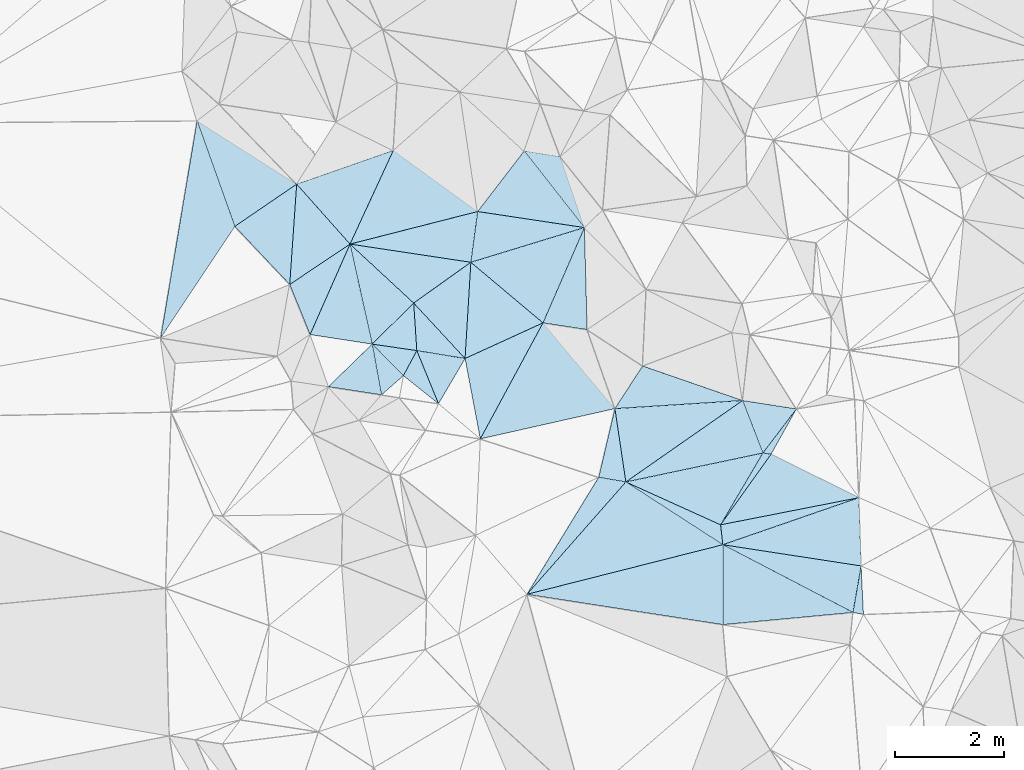
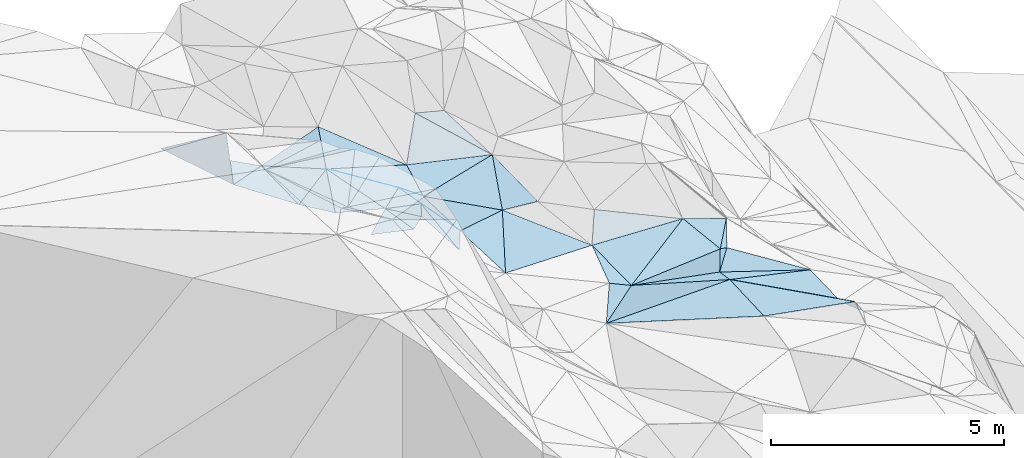
# One storey, part 135 of 275: 45 plates.
"""IFC2X3 building model written with IfcOpenShell, lengths in millimetres."""

import ifcopenshell
import ifcopenshell.guid

model = None  # the IFC model being written
_history = None  # IfcOwnerHistory: only IFC2X3 demands one
_inside = {}  # id of a spatial element -> (the spatial element, [elements in it])
_under = {}  # id of a project, library or spatial element -> (it, [spatial elements below it])
_declared = {}  # id of a project -> (the project, [libraries it declares])
_typed = {}  # id of a type object -> (the type object, [elements of that type])
_made_of = {}  # id of a material, layer set ... -> (it, [elements and type objects made of it])


def new_model(schema):
    """Start an empty IFC model of exactly this schema.

    Asked for "IFC4X3", IfcOpenShell would pick the latest addendum, in which some entities
    have other attributes; the version numbers below select the first issue.
    IFC2X3 requires an IfcOwnerHistory on every rooted entity: one is made here for all.
    """
    global model, _history
    if schema == "IFC4X3":
        model = ifcopenshell.file(schema_version=(4, 3, 0, 0))
    else:
        model = ifcopenshell.file(schema=schema)
    _inside.clear()
    _under.clear()
    _declared.clear()
    _typed.clear()
    _made_of.clear()
    _history = None
    if model.schema == "IFC2X3":
        org = make("IfcOrganization", Name="unknown")
        user = make(
            "IfcPersonAndOrganization",
            ThePerson=make("IfcPerson", FamilyName="unknown"),
            TheOrganization=org,
        )
        app = make(
            "IfcApplication",
            ApplicationDeveloper=org,
            Version="unknown",
            ApplicationFullName="unknown",
            ApplicationIdentifier="unknown",
        )
        _history = make(
            "IfcOwnerHistory",
            OwningUser=user,
            OwningApplication=app,
            ChangeAction="ADDED",
            CreationDate=0,
        )
    return model


def make(cls, **values):
    """One entity of the class cls with the attributes given. An attribute that is None is left unset."""
    return model.create_entity(
        cls, **{name: value for name, value in values.items() if value is not None}
    )


def rooted(cls, **values):
    """An entity with a GlobalId (a new one), such as an element, a storey or a relation."""
    return make(cls, GlobalId=ifcopenshell.guid.new(), OwnerHistory=_history, **values)


def si_unit(unit_type, name, prefix=None):
    """IfcSIUnit, for example si_unit("LENGTHUNIT", "METRE", prefix="MILLI")."""
    return make("IfcSIUnit", UnitType=unit_type, Prefix=prefix, Name=name)


def assignment(units):
    """IfcUnitAssignment: the units of a project."""
    return None if units is None else make("IfcUnitAssignment", Units=units)


def point(xyz):
    """IfcCartesianPoint."""
    return None if xyz is None else make("IfcCartesianPoint", Coordinates=xyz)


def direction(xyz):
    """IfcDirection."""
    return None if xyz is None else make("IfcDirection", DirectionRatios=xyz)


def frame(location, z_axis=None, x_axis=None):
    """IfcAxis2Placement3D, a coordinate frame: its origin and axes. An axis left out is left unset."""
    return make(
        "IfcAxis2Placement3D",
        Location=point(location),
        Axis=direction(z_axis),
        RefDirection=direction(x_axis),
    )


def origin_with_axes():
    """The frame at (0, 0, 0) with the z axis (0, 0, 1) and the x axis (1, 0, 0) written out."""
    return frame((0.0, 0.0, 0.0), z_axis=(0.0, 0.0, 1.0), x_axis=(1.0, 0.0, 0.0))


def place(relative_to, where):
    """IfcLocalPlacement: puts the frame where relative to a parent placement (None: the world)."""
    return make(
        "IfcLocalPlacement", PlacementRelTo=relative_to, RelativePlacement=where
    )


def context(
    kind, dimensions, precision=None, world=None, true_north=None, identifier=None
):
    """IfcGeometricRepresentationContext, for example the 3D "Model" context."""
    return make(
        "IfcGeometricRepresentationContext",
        ContextIdentifier=identifier,
        ContextType=kind,
        CoordinateSpaceDimension=dimensions,
        Precision=precision,
        WorldCoordinateSystem=world,
        TrueNorth=true_north,
    )


def subcontext(parent, identifier, kind, view, scale=None):
    """IfcGeometricRepresentationSubContext, for example "Body" below "Model"."""
    return make(
        "IfcGeometricRepresentationSubContext",
        ContextIdentifier=identifier,
        ContextType=kind,
        ParentContext=parent,
        TargetScale=scale,
        TargetView=view,
    )


def project(units=None, contexts=None):
    """IfcProject with its units and contexts."""
    return rooted(
        "IfcProject",
        Name="project",
        RepresentationContexts=contexts,
        UnitsInContext=assignment(units),
    )


def spatial(cls, under=None, at=None, **own):
    """A site, building, storey or space (cls), placed at a placement, below another one or the project."""
    s = rooted(cls, ObjectPlacement=at, **own)
    if under is not None:
        _under.setdefault(under.id(), (under, []))[1].append(s)
    return s


def polyline(points):
    """IfcPolyline through the points."""
    return make("IfcPolyline", Points=[point(p) for p in points])


def outline(outer, holes=None, kind="AREA"):
    """IfcArbitraryClosedProfileDef: a profile drawn as a closed curve; with holes, ...WithVoids."""
    if holes is None:
        return make("IfcArbitraryClosedProfileDef", ProfileType=kind, OuterCurve=outer)
    return make(
        "IfcArbitraryProfileDefWithVoids",
        ProfileType=kind,
        OuterCurve=outer,
        InnerCurves=holes,
    )


def extrude(swept, where, along, depth):
    """IfcExtrudedAreaSolid: the profile swept, set in the frame where, extruded along a direction by depth."""
    return make(
        "IfcExtrudedAreaSolid",
        SweptArea=swept,
        Position=where,
        ExtrudedDirection=direction(along),
        Depth=depth,
    )


def shape(context_of_items, identifier, shape_type, items):
    """IfcShapeRepresentation: the items that make up one representation, for example the "Body"."""
    return make(
        "IfcShapeRepresentation",
        ContextOfItems=context_of_items,
        RepresentationIdentifier=identifier,
        RepresentationType=shape_type,
        Items=items,
    )


def material(Name=None, Category=None):
    """IfcMaterial."""
    return make("IfcMaterial", Name=Name, Category=Category)


def made_of(thing, what):
    """Note that an element or type object is made of a material, layer set ...; save() writes the relation."""
    if what is not None:
        _made_of.setdefault(what.id(), (what, []))[1].append(thing)
    return thing


def type_object(cls, material=None, **own):
    """A type object (cls), such as IfcWallType, which elements share."""
    return made_of(rooted(cls, **own), material)


def element(
    cls,
    number,
    at=None,
    inside=None,
    cuts=None,
    type_object=None,
    material=None,
    context=None,
    identifier="Body",
    shape_type=None,
    held_by="IfcProductDefinitionShape",
    body=None,
    shapes=None,
    **own,
):
    """One element of the class cls, such as IfcWall. Its Tag is "e" and its number.

    at: its placement. inside: the storey or other place that contains it. cuts: it is an
    opening in that element (IfcRelVoidsElement). A single representation is given by context,
    identifier, shape_type and body (its items); several are given by shapes. held_by: the class
    of the entity that holds the representations. save() writes the other relations.
    """
    e = rooted(cls, Tag="e%d" % number, ObjectPlacement=at, **own)
    if body is not None:
        shapes = [shape(context, identifier, shape_type, body)]
    if shapes is not None:
        e.Representation = make(held_by, Representations=shapes)
    if inside is not None:
        _inside.setdefault(inside.id(), (inside, []))[1].append(e)
    if cuts is not None:
        rooted(
            "IfcRelVoidsElement", RelatingBuildingElement=cuts, RelatedOpeningElement=e
        )
    if type_object is not None:
        _typed.setdefault(type_object.id(), (type_object, []))[1].append(e)
    return made_of(e, material)


def aggregate(whole, parts):
    """IfcRelAggregates: a whole, such as a stair, and the parts it consists of."""
    return rooted("IfcRelAggregates", RelatingObject=whole, RelatedObjects=parts)


def save(model, path):
    """Write the relations noted so far, then the file.

    IfcRelAggregates (storeys below a building ...), IfcRelContainedInSpatialStructure (elements
    in a storey), IfcRelDefinesByType, IfcRelAssociatesMaterial and IfcRelDeclares: one each for
    every whole, place, type object, material and project.
    """
    for whole, parts in _under.values():
        aggregate(whole, parts)
    for where, things in _inside.values():
        rooted(
            "IfcRelContainedInSpatialStructure",
            RelatedElements=things,
            RelatingStructure=where,
        )
    for kind, things in _typed.values():
        rooted("IfcRelDefinesByType", RelatedObjects=things, RelatingType=kind)
    for what, things in _made_of.values():
        rooted("IfcRelAssociatesMaterial", RelatedObjects=things, RelatingMaterial=what)
    for by, libraries in _declared.values():
        rooted("IfcRelDeclares", RelatingContext=by, RelatedDefinitions=libraries)
    model.write(path)


model = new_model("IFC2X3")

# Units and contexts
model_context = context("Model", 3, precision=1e-05, world=origin_with_axes())
body_context = subcontext(model_context, "Body", "Model", "MODEL_VIEW")
ifc_project = project(units=[si_unit("LENGTHUNIT", "METRE", prefix="MILLI"), si_unit("AREAUNIT", "SQUARE_METRE"), si_unit("VOLUMEUNIT", "CUBIC_METRE"), si_unit("MASSUNIT", "GRAM", prefix="KILO"), si_unit("TIMEUNIT", "SECOND"), si_unit("PLANEANGLEUNIT", "RADIAN"), si_unit("SOLIDANGLEUNIT", "STERADIAN"), si_unit("THERMODYNAMICTEMPERATUREUNIT", "DEGREE_CELSIUS"), si_unit("LUMINOUSINTENSITYUNIT", "LUMEN")], contexts=[model_context])

# Site, building, storey
site_placement = place(None, origin_with_axes())
site = spatial("IfcSite", under=ifc_project, at=site_placement, CompositionType="ELEMENT")
building_placement = place(site_placement, origin_with_axes())
building = spatial("IfcBuilding", under=site, at=building_placement, Name="Undefined", CompositionType="ELEMENT")
storey_placement = place(building_placement, origin_with_axes())
storey = spatial("IfcBuildingStorey", under=building, at=storey_placement, Name="Undefined", CompositionType="ELEMENT", Elevation=0.0)

# Plates
ifc_material = material()
plate_type_1 = type_object("IfcPlateType", PredefinedType="NOTDEFINED")
plate_1_placement = place(storey_placement, frame((-107710.69176452, 128511.918130305, 52359.5023639897), z_axis=(-0.0371328837966639, 0.0902431550285866, -0.995227271486986), x_axis=(-0.762830735926998, 0.640777467398013, 0.0865650368223972)))
element("IfcPlate", 1, at=plate_1_placement, inside=storey, type_object=plate_type_1, material=ifc_material, Name="00", context=body_context, shape_type="SweptSolid", body=[
    extrude(outline(polyline([(0.0, 0.0), (1732.80114746094, -1.14378053694963e-08), (551.130737304688, 1826.81555175781), (0.0, 0.0)])), frame((-8.85201319254618e-08, 2.18876761149539e-07, -0.5000001331573), z_axis=(0.0, 0.0, 1.0), x_axis=(1.0, 0.0, 0.0)), (0.0, 0.0, 1.0), 1.0),
])
plate_type_2 = type_object("IfcPlateType", PredefinedType="NOTDEFINED")
plate_2_placement = place(storey_placement, frame((-109138.864228995, 127858.741128758, 52709.6383195385), z_axis=(-0.689324173895359, -0.0405942990156006, -0.723314790510268), x_axis=(-0.58104888926832, 0.627295977761669, 0.518538276855318)))
element("IfcPlate", 2, at=plate_2_placement, inside=storey, type_object=plate_type_2, material=ifc_material, Name="00", context=body_context, shape_type="SweptSolid", body=[
    extrude(outline(polyline([(0.0, 0.0), (1619.93823242188, -3.40151018463075e-09), (940.900024414063, 1508.54467773438), (0.0, 0.0)])), frame((-8.85201319254618e-08, 2.18876761149539e-07, -0.5000001331573), z_axis=(0.0, 0.0, 1.0), x_axis=(1.0, 0.0, 0.0)), (0.0, 0.0, 1.0), 1.0),
])
plate_type_3 = type_object("IfcPlateType", PredefinedType="NOTDEFINED")
plate_3_placement = place(storey_placement, frame((-106192.409003258, 125596.978377253, 51619.5136560321), z_axis=(-0.100611439804562, 0.209387360971227, -0.972642931011149), x_axis=(-0.143834742344254, 0.964272473574274, 0.222463847853337)))
element("IfcPlate", 3, at=plate_3_placement, inside=storey, type_object=plate_type_3, material=ifc_material, Name="00", context=body_context, shape_type="SweptSolid", body=[
    extrude(outline(polyline([(0.0, 0.0), (1393.48486328125, 1.04482751339674e-08), (1153.65441894531, 2341.5126953125), (0.0, 0.0)])), frame((-8.85201319254618e-08, 2.18876761149539e-07, -0.5000001331573), z_axis=(0.0, 0.0, 1.0), x_axis=(1.0, 0.0, 0.0)), (0.0, 0.0, 1.0), 1.0),
])
plate_type_4 = type_object("IfcPlateType", PredefinedType="NOTDEFINED")
plate_4_placement = place(storey_placement, frame((-108859.292674033, 126386.029390544, 52399.5278280914), z_axis=(-0.296645922713064, 0.142488007224602, -0.944297815487718), x_axis=(-0.182504648304248, 0.962123439443059, 0.2025105938503)))
element("IfcPlate", 4, at=plate_4_placement, inside=storey, type_object=plate_type_4, material=ifc_material, Name="00", context=body_context, shape_type="SweptSolid", body=[
    extrude(outline(polyline([(0.0, 0.0), (1530.78405761719, 7.29050952941179e-09), (1827.69079589844, 1581.02697753906), (0.0, 0.0)])), frame((-8.85201319254618e-08, 2.18876761149539e-07, -0.5000001331573), z_axis=(0.0, 0.0, 1.0), x_axis=(1.0, 0.0, 0.0)), (0.0, 0.0, 1.0), 1.0),
])
plate_type_5 = type_object("IfcPlateType", PredefinedType="NOTDEFINED")
plate_5_placement = place(storey_placement, frame((-101921.569591714, 125309.296885175, 50709.5498930315), z_axis=(-0.431603792133785, 0.0584415224361357, -0.900168181547806), x_axis=(0.0311991043474354, -0.996335009214666, -0.0796439909919763)))
element("IfcPlate", 5, at=plate_5_placement, inside=storey, type_object=plate_type_5, material=ifc_material, Name="00", context=body_context, shape_type="SweptSolid", body=[
    extrude(outline(polyline([(0.0, 0.0), (1255.58752441406, 9.02218744158745e-10), (690.433776855469, 2790.73486328125), (0.0, 0.0)])), frame((-8.85201319254618e-08, 2.18876761149539e-07, -0.5000001331573), z_axis=(0.0, 0.0, 1.0), x_axis=(1.0, 0.0, 0.0)), (0.0, 0.0, 1.0), 1.0),
])
plate_type_6 = type_object("IfcPlateType", PredefinedType="NOTDEFINED")
plate_6_placement = place(storey_placement, frame((-104413.620050964, 122982.94455354, 51779.5098386131), z_axis=(-0.192062091809998, 0.0465779168700106, -0.980276823427759), x_axis=(-0.968897039972385, 0.149828539683579, 0.196951604789191)))
element("IfcPlate", 6, at=plate_6_placement, inside=storey, type_object=plate_type_6, material=ifc_material, Name="00", context=body_context, shape_type="SweptSolid", body=[
    extrude(outline(polyline([(0.0, 0.0), (3706.49438476563, 1.20489858090878e-08), (235.28971862793, 1446.80297851563), (0.0, 0.0)])), frame((-8.85201319254618e-08, 2.18876761149539e-07, -0.5000001331573), z_axis=(0.0, 0.0, 1.0), x_axis=(1.0, 0.0, 0.0)), (0.0, 0.0, 1.0), 1.0),
])
plate_type_7 = type_object("IfcPlateType", PredefinedType="NOTDEFINED")
plate_7_placement = place(storey_placement, frame((-106392.944822617, 126940.657635162, 51929.5321163041), z_axis=(-0.309209619517044, 0.169753804659345, -0.935720608409263), x_axis=(0.143834742311184, -0.964272473579365, -0.222463847852651)))
element("IfcPlate", 7, at=plate_7_placement, inside=storey, type_object=plate_type_7, material=ifc_material, Name="00", context=body_context, shape_type="SweptSolid", body=[
    extrude(outline(polyline([(0.0, 0.0), (1393.48486328125, 1.04482751339674e-08), (1198.72131347656, 499.266632080078), (0.0, 0.0)])), frame((-8.85201319254618e-08, 2.18876761149539e-07, -0.5000001331573), z_axis=(0.0, 0.0, 1.0), x_axis=(1.0, 0.0, 0.0)), (0.0, 0.0, 1.0), 1.0),
])
plate_type_8 = type_object("IfcPlateType", PredefinedType="NOTDEFINED")
plate_8_placement = place(storey_placement, frame((-111246.436842122, 129955.526503415, 53799.512210554), z_axis=(-0.219560814222345, -0.0113309706009984, -0.975533012236521), x_axis=(0.724715379181477, -0.671316362592735, -0.155312460842994)))
element("IfcPlate", 8, at=plate_8_placement, inside=storey, type_object=plate_type_8, material=ifc_material, Name="00", context=body_context, shape_type="SweptSolid", body=[
    extrude(outline(polyline([(0.0, 0.0), (1609.65832519531, -3.08500602841377e-09), (1534.98413085938, 1082.23095703125), (0.0, 0.0)])), frame((-8.85201319254618e-08, 2.18876761149539e-07, -0.5000001331573), z_axis=(0.0, 0.0, 1.0), x_axis=(1.0, 0.0, 0.0)), (0.0, 0.0, 1.0), 1.0),
])
plate_type_9 = type_object("IfcPlateType", PredefinedType="NOTDEFINED")
plate_9_placement = place(storey_placement, frame((-112223.908202513, 131053.984974895, 53559.5071888901), z_axis=(0.146227209778947, -0.0851880249528446, -0.985576279911858), x_axis=(0.656143795974726, -0.737245238415786, 0.161073826046096)))
element("IfcPlate", 9, at=plate_9_placement, inside=storey, type_object=plate_type_9, material=ifc_material, Name="00", context=body_context, shape_type="SweptSolid", body=[
    extrude(outline(polyline([(0.0, 0.0), (1490.0, 3.95539245801046e-09), (1294.36242675781, 1319.36572265625), (0.0, 0.0)])), frame((-8.85201319254618e-08, 2.18876761149539e-07, -0.5000001331573), z_axis=(0.0, 0.0, 1.0), x_axis=(1.0, 0.0, 0.0)), (0.0, 0.0, 1.0), 1.0),
])
plate_type_10 = type_object("IfcPlateType", PredefinedType="NOTDEFINED")
plate_10_placement = place(storey_placement, frame((-102030.288369506, 123205.455464031, 51189.6131706941), z_axis=(-0.447477321364182, -0.448650769825437, -0.773612650878836), x_axis=(-0.861524801288728, 0.448293993777246, 0.238343264867428)))
element("IfcPlate", 10, at=plate_10_placement, inside=storey, type_object=plate_type_10, material=ifc_material, Name="00", context=body_context, shape_type="SweptSolid", body=[
    extrude(outline(polyline([(0.0, 0.0), (2769.11547851563, -1.03682396002114e-08), (116.57152557373, 1035.1865234375), (0.0, 0.0)])), frame((-8.85201319254618e-08, 2.18876761149539e-07, -0.5000001331573), z_axis=(0.0, 0.0, 1.0), x_axis=(1.0, 0.0, 0.0)), (0.0, 0.0, 1.0), 1.0),
])
plate_type_11 = type_object("IfcPlateType", PredefinedType="NOTDEFINED")
plate_11_placement = place(storey_placement, frame((-103682.49230924, 126127.162952142, 51379.5272046954), z_axis=(-0.19937264125571, 0.257278735910264, -0.945546509679528), x_axis=(-0.341441807250448, 0.886210075497294, 0.313128079783064)))
element("IfcPlate", 11, at=plate_11_placement, inside=storey, type_object=plate_type_11, material=ifc_material, Name="00", context=body_context, shape_type="SweptSolid", body=[
    extrude(outline(polyline([(0.0, 0.0), (1085.81762695313, -9.53150447458029e-10), (533.975463867188, 869.005310058594), (0.0, 0.0)])), frame((-8.85201319254618e-08, 2.18876761149539e-07, -0.5000001331573), z_axis=(0.0, 0.0, 1.0), x_axis=(1.0, 0.0, 0.0)), (0.0, 0.0, 1.0), 1.0),
])
plate_type_12 = type_object("IfcPlateType", PredefinedType="NOTDEFINED")
plate_12_placement = place(storey_placement, frame((-101882.599243838, 124058.181508393, 50609.7457046321), z_axis=(-0.83731341803122, -0.20071661937462, -0.508546043826613), x_axis=(0.0460346862465202, -0.952751163974088, 0.30024328003838)))
element("IfcPlate", 12, at=plate_12_placement, inside=storey, type_object=plate_type_12, material=ifc_material, Name="00", context=body_context, shape_type="SweptSolid", body=[
    extrude(outline(polyline([(0.0, 0.0), (932.577087402344, -4.13274392485619e-09), (979.650939941406, 354.237274169922), (0.0, 0.0)])), frame((-8.85201319254618e-08, 2.18876761149539e-07, -0.5000001331573), z_axis=(0.0, 0.0, 1.0), x_axis=(1.0, 0.0, 0.0)), (0.0, 0.0, 1.0), 1.0),
])
plate_type_13 = type_object("IfcPlateType", PredefinedType="NOTDEFINED")
plate_13_placement = place(storey_placement, frame((-103066.543422273, 126935.130052878, 51469.5057783137), z_axis=(-0.0456164725970412, 0.14485958604329, -0.988400140509485), x_axis=(-0.486392299623848, -0.867446613134529, -0.104684785083886)))
element("IfcPlate", 13, at=plate_13_placement, inside=storey, type_object=plate_type_13, material=ifc_material, Name="00", context=body_context, shape_type="SweptSolid", body=[
    extrude(outline(polyline([(0.0, 0.0), (955.248657226563, 4.16184775531292e-09), (1009.89410400391, 142.877136230469), (0.0, 0.0)])), frame((-8.85201319254618e-08, 2.18876761149539e-07, -0.5000001331573), z_axis=(0.0, 0.0, 1.0), x_axis=(1.0, 0.0, 0.0)), (0.0, 0.0, 1.0), 1.0),
])
plate_type_14 = type_object("IfcPlateType", PredefinedType="NOTDEFINED")
plate_14_placement = place(storey_placement, frame((-104415.923575617, 124447.0228709, 51849.5418899047), z_axis=(-0.394721021591551, -0.0694235471478252, -0.916174484590755), x_axis=(-0.111476295290039, 0.993393499615418, -0.0272468440418521)))
element("IfcPlate", 14, at=plate_14_placement, inside=storey, type_object=plate_type_14, material=ifc_material, Name="00", context=body_context, shape_type="SweptSolid", body=[
    extrude(outline(polyline([(0.0, 0.0), (367.014984130859, 1.74622982740402e-10), (609.511901855469, 2809.51879882813), (0.0, 0.0)])), frame((-8.85201319254618e-08, 2.18876761149539e-07, -0.5000001331573), z_axis=(0.0, 0.0, 1.0), x_axis=(1.0, 0.0, 0.0)), (0.0, 0.0, 1.0), 1.0),
])
plate_type_15 = type_object("IfcPlateType", PredefinedType="NOTDEFINED")
plate_15_placement = place(storey_placement, frame((-106192.298893779, 125596.866780237, 51619.5036124573), z_axis=(0.119579598986386, -0.0138096633752407, -0.992728569501109), x_axis=(0.905088959457991, -0.409455218850992, 0.114718783217644)))
element("IfcPlate", 15, at=plate_15_placement, inside=storey, type_object=plate_type_15, material=ifc_material, Name="00", context=body_context, shape_type="SweptSolid", body=[
    extrude(outline(polyline([(0.0, 0.0), (1917.73303222656, 7.21047399565578e-09), (2105.19384765625, 315.528778076172), (0.0, 0.0)])), frame((-8.85201319254618e-08, 2.18876761149539e-07, -0.5000001331573), z_axis=(0.0, 0.0, 1.0), x_axis=(1.0, 0.0, 0.0)), (0.0, 0.0, 1.0), 1.0),
])
plate_type_16 = type_object("IfcPlateType", PredefinedType="NOTDEFINED")
plate_16_placement = place(storey_placement, frame((-110022.94209053, 128003.794313233, 53639.6571778109), z_axis=(-0.67758261083665, 0.266154383681488, -0.685597293999121), x_axis=(0.684637176254485, -0.112210861787077, -0.720194875979611)))
element("IfcPlate", 16, at=plate_16_placement, inside=storey, type_object=plate_type_16, material=ifc_material, Name="00", context=body_context, shape_type="SweptSolid", body=[
    extrude(outline(polyline([(0.0, 0.0), (1291.31713867188, -1.12049747258425e-09), (935.556396484375, 906.109436035156), (0.0, 0.0)])), frame((-8.85201319254618e-08, 2.18876761149539e-07, -0.5000001331573), z_axis=(0.0, 0.0, 1.0), x_axis=(1.0, 0.0, 0.0)), (0.0, 0.0, 1.0), 1.0),
])
plate_type_17 = type_object("IfcPlateType", PredefinedType="NOTDEFINED")
plate_17_placement = place(storey_placement, frame((-106951.869947231, 130257.97231562, 52489.5336451602), z_axis=(-0.0870696218427349, 0.350076869679344, -0.932665570431157), x_axis=(-0.582117858409149, 0.741874698825419, 0.332807346919866)))
element("IfcPlate", 17, at=plate_17_placement, inside=storey, type_object=plate_type_17, material=ifc_material, Name="00", context=body_context, shape_type="SweptSolid", body=[
    extrude(outline(polyline([(0.0, 0.0), (1892.98706054688, -1.81807990884408e-09), (1400.53784179688, 459.013916015625), (0.0, 0.0)])), frame((-8.85201319254618e-08, 2.18876761149539e-07, -0.5000001331573), z_axis=(0.0, 0.0, 1.0), x_axis=(1.0, 0.0, 0.0)), (0.0, 0.0, 1.0), 1.0),
])
plate_type_18 = type_object("IfcPlateType", PredefinedType="NOTDEFINED")
plate_18_placement = place(storey_placement, frame((-108908.052606234, 130552.158248969, 52729.5747717883), z_axis=(-0.456034506919766, 0.262364102578801, -0.850410257567761), x_axis=(-0.129394258568156, -0.964950796215138, -0.228313571067005)))
element("IfcPlate", 18, at=plate_18_placement, inside=storey, type_object=plate_type_18, material=ifc_material, Name="00", context=body_context, shape_type="SweptSolid", body=[
    extrude(outline(polyline([(0.0, 0.0), (963.587036132813, -1.99361238628626e-09), (633.881469726563, 2562.71240234375), (0.0, 0.0)])), frame((-8.85201319254618e-08, 2.18876761149539e-07, -0.5000001331573), z_axis=(0.0, 0.0, 1.0), x_axis=(1.0, 0.0, 0.0)), (0.0, 0.0, 1.0), 1.0),
])
plate_type_19 = type_object("IfcPlateType", PredefinedType="NOTDEFINED")
plate_19_placement = place(storey_placement, frame((-109032.60418286, 129622.163461006, 52509.5119771392), z_axis=(-0.19394303412334, -0.099033004496561, -0.976001313285703), x_axis=(0.7628307359109, -0.640777467415803, -0.0865650368325726)))
element("IfcPlate", 19, at=plate_19_placement, inside=storey, type_object=plate_type_19, material=ifc_material, Name="00", context=body_context, shape_type="SweptSolid", body=[
    extrude(outline(polyline([(0.0, 0.0), (1732.80114746094, -1.14378053694963e-08), (1031.79748535156, 1447.89294433594), (0.0, 0.0)])), frame((-8.85201319254618e-08, 2.18876761149539e-07, -0.5000001331573), z_axis=(0.0, 0.0, 1.0), x_axis=(1.0, 0.0, 0.0)), (0.0, 0.0, 1.0), 1.0),
])
plate_type_20 = type_object("IfcPlateType", PredefinedType="NOTDEFINED")
plate_20_placement = place(storey_placement, frame((-112351.601586963, 129215.455462931, 53699.5202054746), z_axis=(-0.276351274516629, -0.0539047341042547, -0.959543773214221), x_axis=(-0.678748515118949, 0.717792830565209, 0.155157679838953)))
element("IfcPlate", 20, at=plate_20_placement, inside=storey, type_object=plate_type_20, material=ifc_material, Name="00", context=body_context, shape_type="SweptSolid", body=[
    extrude(outline(polyline([(0.0, 0.0), (1482.36303710938, -5.63522917218506e-09), (1211.44421386719, 1395.88793945313), (0.0, 0.0)])), frame((-8.85201319254618e-08, 2.18876761149539e-07, -0.5000001331573), z_axis=(0.0, 0.0, 1.0), x_axis=(1.0, 0.0, 0.0)), (0.0, 0.0, 1.0), 1.0),
])
plate_type_21 = type_object("IfcPlateType", PredefinedType="NOTDEFINED")
plate_21_placement = place(storey_placement, frame((-111978.508396134, 128297.817670376, 53909.5142216789), z_axis=(0.186145274977687, -0.14669965099236, -0.971508697337395), x_axis=(-0.368268814486867, 0.906287971329557, -0.207413098187637)))
element("IfcPlate", 21, at=plate_21_placement, inside=storey, type_object=plate_type_21, material=ifc_material, Name="00", context=body_context, shape_type="SweptSolid", body=[
    extrude(outline(polyline([(0.0, 0.0), (1012.47222900391, -2.85945134237409e-09), (1255.44189453125, 1311.474609375), (0.0, 0.0)])), frame((-8.85201319254618e-08, 2.18876761149539e-07, -0.5000001331573), z_axis=(0.0, 0.0, 1.0), x_axis=(1.0, 0.0, 0.0)), (0.0, 0.0, 1.0), 1.0),
])
plate_type_22 = type_object("IfcPlateType", PredefinedType="NOTDEFINED")
plate_22_placement = place(storey_placement, frame((-110840.794599613, 128123.044869742, 53729.5030309187), z_axis=(-0.110209174858559, -0.00599720173340255, -0.99389032158904), x_axis=(0.983709166232913, -0.143547891659334, -0.108214042847996)))
element("IfcPlate", 22, at=plate_22_placement, inside=storey, type_object=plate_type_22, material=ifc_material, Name="00", context=body_context, shape_type="SweptSolid", body=[
    extrude(outline(polyline([(0.0, 0.0), (831.68505859375, 2.11002770811319e-09), (652.650939941406, 489.230804443359), (0.0, 0.0)])), frame((-8.85201319254618e-08, 2.18876761149539e-07, -0.5000001331573), z_axis=(0.0, 0.0, 1.0), x_axis=(1.0, 0.0, 0.0)), (0.0, 0.0, 1.0), 1.0),
])
plate_type_23 = type_object("IfcPlateType", PredefinedType="NOTDEFINED")
plate_23_placement = place(storey_placement, frame((-110080.037277147, 128874.757531884, 53549.6111403637), z_axis=(-0.508757562026395, -0.369307019714275, -0.777674783100699), x_axis=(-0.724715379162451, 0.671316362611713, 0.155312460849748)))
element("IfcPlate", 23, at=plate_23_placement, inside=storey, type_object=plate_type_23, material=ifc_material, Name="00", context=body_context, shape_type="SweptSolid", body=[
    extrude(outline(polyline([(0.0, 0.0), (1609.65832519531, -3.08500602841377e-09), (-418.846649169922, 1600.42724609375), (0.0, 0.0)])), frame((-8.85201319254618e-08, 2.18876761149539e-07, -0.5000001331573), z_axis=(0.0, 0.0, 1.0), x_axis=(1.0, 0.0, 0.0)), (0.0, 0.0, 1.0), 1.0),
])
plate_type_24 = type_object("IfcPlateType", PredefinedType="NOTDEFINED")
plate_24_placement = place(storey_placement, frame((-110080.147312797, 128874.883430142, 53549.6627093366), z_axis=(-0.728829227932888, -0.11750798853323, -0.674536751512937), x_axis=(0.581048889289267, -0.627295977731706, -0.518538276868094)))
element("IfcPlate", 24, at=plate_24_placement, inside=storey, type_object=plate_type_24, material=ifc_material, Name="00", context=body_context, shape_type="SweptSolid", body=[
    extrude(outline(polyline([(0.0, 0.0), (1619.93823242188, -3.40151018463075e-09), (533.106750488281, 697.350158691406), (0.0, 0.0)])), frame((-8.85201319254618e-08, 2.18876761149539e-07, -0.5000001331573), z_axis=(0.0, 0.0, 1.0), x_axis=(1.0, 0.0, 0.0)), (0.0, 0.0, 1.0), 1.0),
])
plate_type_25 = type_object("IfcPlateType", PredefinedType="NOTDEFINED")
plate_25_placement = place(storey_placement, frame((-104415.848252721, 124447.080551581, 51849.5156435594), z_axis=(-0.244077155135081, 0.0459446110181007, -0.968666833880236), x_axis=(0.861524801289478, -0.448293993782753, -0.23834326485436)))
element("IfcPlate", 25, at=plate_25_placement, inside=storey, type_object=plate_type_25, material=ifc_material, Name="00", context=body_context, shape_type="SweptSolid", body=[
    extrude(outline(polyline([(0.0, 0.0), (2769.11547851563, -1.03682396002114e-08), (674.944763183594, 1301.17236328125), (0.0, 0.0)])), frame((-8.85201319254618e-08, 2.18876761149539e-07, -0.5000001331573), z_axis=(0.0, 0.0, 1.0), x_axis=(1.0, 0.0, 0.0)), (0.0, 0.0, 1.0), 1.0),
])
plate_type_26 = type_object("IfcPlateType", PredefinedType="NOTDEFINED")
plate_26_placement = place(storey_placement, frame((-105885.665519266, 127722.613510386, 52219.5462416368), z_axis=(-0.107271791205354, 0.406187473111037, -0.907471486879486), x_axis=(0.915231654871099, -0.316209133586351, -0.249725452764588)))
element("IfcPlate", 26, at=plate_26_placement, inside=storey, type_object=plate_type_26, material=ifc_material, Name="00", context=body_context, shape_type="SweptSolid", body=[
    extrude(outline(polyline([(0.0, 0.0), (2002.19873046875, -3.92901711165905e-10), (-144.541091918945, 965.250183105469), (0.0, 0.0)])), frame((-8.85201319254618e-08, 2.18876761149539e-07, -0.5000001331573), z_axis=(0.0, 0.0, 1.0), x_axis=(1.0, 0.0, 0.0)), (0.0, 0.0, 1.0), 1.0),
])
plate_type_27 = type_object("IfcPlateType", PredefinedType="NOTDEFINED")
plate_27_placement = place(storey_placement, frame((-110079.84516639, 128874.887169671, 53549.5069288135), z_axis=(-0.124533081644096, -0.110032644239287, -0.986095496784128), x_axis=(0.0651410563437176, -0.992594574142716, 0.102531235049936)))
element("IfcPlate", 27, at=plate_27_placement, inside=storey, type_object=plate_type_27, material=ifc_material, Name="00", context=body_context, shape_type="SweptSolid", body=[
    extrude(outline(polyline([(0.0, 0.0), (877.781311035156, -5.77711034566164e-09), (715.212341308594, 815.641662597656), (0.0, 0.0)])), frame((-8.85201319254618e-08, 2.18876761149539e-07, -0.5000001331573), z_axis=(0.0, 0.0, 1.0), x_axis=(1.0, 0.0, 0.0)), (0.0, 0.0, 1.0), 1.0),
])
plate_type_28 = type_object("IfcPlateType", PredefinedType="NOTDEFINED")
plate_28_placement = place(storey_placement, frame((-110669.994525694, 127192.668219672, 53689.5016015926), z_axis=(-0.0751237112803634, 0.0290631719047779, -0.996750600723319), x_axis=(-0.180381721378703, 0.982688921876687, 0.0422482829626314)))
element("IfcPlate", 28, at=plate_28_placement, inside=storey, type_object=plate_type_28, material=ifc_material, Name="00", context=body_context, shape_type="SweptSolid", body=[
    extrude(outline(polyline([(0.0, 0.0), (946.784057617188, -3.73984221369028e-09), (273.135162353516, 459.888244628906), (0.0, 0.0)])), frame((-8.85201319254618e-08, 2.18876761149539e-07, -0.5000001331573), z_axis=(0.0, 0.0, 1.0), x_axis=(1.0, 0.0, 0.0)), (0.0, 0.0, 1.0), 1.0),
])
plate_type_29 = type_object("IfcPlateType", PredefinedType="NOTDEFINED")
plate_29_placement = place(storey_placement, frame((-108053.797015686, 131662.341661017, 53119.5364376909), z_axis=(-0.0580429282889367, 0.370346502902279, -0.927078468234322), x_axis=(0.582117858437962, -0.74187469880005, -0.332807346926021)))
element("IfcPlate", 29, at=plate_29_placement, inside=storey, type_object=plate_type_29, material=ifc_material, Name="00", context=body_context, shape_type="SweptSolid", body=[
    extrude(outline(polyline([(0.0, 0.0), (1892.98706054688, -1.81807990884408e-09), (456.210205078125, 1380.4970703125), (0.0, 0.0)])), frame((-8.85201319254618e-08, 2.18876761149539e-07, -0.5000001331573), z_axis=(0.0, 0.0, 1.0), x_axis=(1.0, 0.0, 0.0)), (0.0, 0.0, 1.0), 1.0),
])
plate_type_30 = type_object("IfcPlateType", PredefinedType="NOTDEFINED")
plate_30_placement = place(storey_placement, frame((-109625.801628959, 127031.34218909, 52869.6465767008), z_axis=(-0.641787114081389, 0.29756072027259, -0.70680047959091), x_axis=(-0.559990311250663, 0.447848856772664, 0.697023853819081)))
element("IfcPlate", 30, at=plate_30_placement, inside=storey, type_object=plate_type_30, material=ifc_material, Name="00", context=body_context, shape_type="SweptSolid", body=[
    extrude(outline(polyline([(0.0, 0.0), (1147.73693847656, -4.23460733145475e-09), (1194.61181640625, 518.847534179688), (0.0, 0.0)])), frame((-8.85201319254618e-08, 2.18876761149539e-07, -0.5000001331573), z_axis=(0.0, 0.0, 1.0), x_axis=(1.0, 0.0, 0.0)), (0.0, 0.0, 1.0), 1.0),
])
plate_type_31 = type_object("IfcPlateType", PredefinedType="NOTDEFINED")
plate_31_placement = place(storey_placement, frame((-106689.886356591, 125683.093456045, 51799.5344095762), z_axis=(-0.352924010414434, -0.0918468465101082, -0.931133073013273), x_axis=(0.928049122759423, -0.160970355640773, -0.335877016704549)))
element("IfcPlate", 31, at=plate_31_placement, inside=storey, type_object=plate_type_31, material=ifc_material, Name="00", context=body_context, shape_type="SweptSolid", body=[
    extrude(outline(polyline([(0.0, 0.0), (535.910461425781, -6.54836185276508e-10), (-1113.61889648438, 2365.11157226563), (0.0, 0.0)])), frame((-8.85201319254618e-08, 2.18876761149539e-07, -0.5000001331573), z_axis=(0.0, 0.0, 1.0), x_axis=(1.0, 0.0, 0.0)), (0.0, 0.0, 1.0), 1.0),
])
plate_type_32 = type_object("IfcPlateType", PredefinedType="NOTDEFINED")
plate_32_placement = place(storey_placement, frame((-104456.651455752, 124811.489067986, 51839.5260163978), z_axis=(-0.0235476419954862, -0.317634337516375, -0.947920849115044), x_axis=(-0.905088959454304, 0.409455218860079, -0.114718783214303)))
element("IfcPlate", 32, at=plate_32_placement, inside=storey, type_object=plate_type_32, material=ifc_material, Name="00", context=body_context, shape_type="SweptSolid", body=[
    extrude(outline(polyline([(0.0, 0.0), (1917.73303222656, 7.21047399565578e-09), (-109.400001525879, 1590.38720703125), (0.0, 0.0)])), frame((-8.85201319254618e-08, 2.18876761149539e-07, -0.5000001331573), z_axis=(0.0, 0.0, 1.0), x_axis=(1.0, 0.0, 0.0)), (0.0, 0.0, 1.0), 1.0),
])
plate_type_33 = type_object("IfcPlateType", PredefinedType="NOTDEFINED")
plate_33_placement = place(storey_placement, frame((-106192.403723275, 125596.710012606, 51619.5296755631), z_axis=(-0.090083233391673, -0.327342136523394, -0.940602007608958), x_axis=(0.834605792998623, -0.54014727062862, 0.108046732137495)))
element("IfcPlate", 33, at=plate_33_placement, inside=storey, type_object=plate_type_33, material=ifc_material, Name="00", context=body_context, shape_type="SweptSolid", body=[
    extrude(outline(polyline([(0.0, 0.0), (2128.70849609375, 9.2186382971704e-09), (-304.503875732422, 2867.39916992188), (0.0, 0.0)])), frame((-8.85201319254618e-08, 2.18876761149539e-07, -0.5000001331573), z_axis=(0.0, 0.0, 1.0), x_axis=(1.0, 0.0, 0.0)), (0.0, 0.0, 1.0), 1.0),
])
plate_type_34 = type_object("IfcPlateType", PredefinedType="NOTDEFINED")
plate_34_placement = place(storey_placement, frame((-110840.793900504, 128123.059243614, 53729.5030757262), z_axis=(-0.10881673458914, 0.0227517106378493, -0.993801427819667), x_axis=(0.180381721366855, -0.982688921880369, -0.0422482829275732)))
element("IfcPlate", 34, at=plate_34_placement, inside=storey, type_object=plate_type_34, material=ifc_material, Name="00", context=body_context, shape_type="SweptSolid", body=[
    extrude(outline(polyline([(0.0, 0.0), (946.784057617188, -3.73984221369028e-09), (619.993530273438, 935.472045898438), (0.0, 0.0)])), frame((-8.85201319254618e-08, 2.18876761149539e-07, -0.5000001331573), z_axis=(0.0, 0.0, 1.0), x_axis=(1.0, 0.0, 0.0)), (0.0, 0.0, 1.0), 1.0),
])
plate_type_35 = type_object("IfcPlateType", PredefinedType="NOTDEFINED")
plate_35_placement = place(storey_placement, frame((-103531.34564601, 126106.406755377, 51369.5420881977), z_axis=(-0.398886320299779, -0.0473049572114613, -0.915779419129369), x_axis=(0.841164731141825, -0.416541404656627, -0.344869762794283)))
element("IfcPlate", 35, at=plate_35_placement, inside=storey, type_object=plate_type_35, material=ifc_material, Name="00", context=body_context, shape_type="SweptSolid", body=[
    extrude(outline(polyline([(0.0, 0.0), (1913.76586914063, 1.4202669262886e-08), (-401.250732421875, 1610.24780273438), (0.0, 0.0)])), frame((-8.85201319254618e-08, 2.18876761149539e-07, -0.5000001331573), z_axis=(0.0, 0.0, 1.0), x_axis=(1.0, 0.0, 0.0)), (0.0, 0.0, 1.0), 1.0),
])
plate_type_36 = type_object("IfcPlateType", PredefinedType="NOTDEFINED")
plate_36_placement = place(storey_placement, frame((-104053.210869848, 127089.435736872, 51719.5254940415), z_axis=(-0.149403920251973, 0.277739572085254, -0.94896743817227), x_axis=(0.341441807246582, -0.886210075500236, -0.313128079778952)))
element("IfcPlate", 36, at=plate_36_placement, inside=storey, type_object=plate_type_36, material=ifc_material, Name="00", context=body_context, shape_type="SweptSolid", body=[
    extrude(outline(polyline([(0.0, 0.0), (1085.81762695313, -9.53150447458029e-10), (623.493286132813, 2534.72998046875), (0.0, 0.0)])), frame((-8.85201319254618e-08, 2.18876761149539e-07, -0.5000001331573), z_axis=(0.0, 0.0, 1.0), x_axis=(1.0, 0.0, 0.0)), (0.0, 0.0, 1.0), 1.0),
])
plate_type_37 = type_object("IfcPlateType", PredefinedType="NOTDEFINED")
plate_37_placement = place(storey_placement, frame((-104456.690047407, 124811.510333388, 51839.5219133871), z_axis=(-0.100692362866627, -0.275096804788963, -0.956129068722021), x_axis=(0.485681550791776, 0.825135722276998, -0.28855583695866)))
element("IfcPlate", 37, at=plate_37_placement, inside=storey, type_object=plate_type_37, material=ifc_material, Name="00", context=body_context, shape_type="SweptSolid", body=[
    extrude(outline(polyline([(0.0, 0.0), (1594.1455078125, -4.71482053399086e-09), (1653.48767089844, 140.991180419922), (0.0, 0.0)])), frame((-8.85201319254618e-08, 2.18876761149539e-07, -0.5000001331573), z_axis=(0.0, 0.0, 1.0), x_axis=(1.0, 0.0, 0.0)), (0.0, 0.0, 1.0), 1.0),
])
plate_type_38 = type_object("IfcPlateType", PredefinedType="NOTDEFINED")
plate_38_placement = place(storey_placement, frame((-106951.809531932, 130257.8270877, 52489.5011528467), z_axis=(0.0337591536352008, 0.059611153370886, -0.997650655259459), x_axis=(0.0267679653875682, -0.997915476612983, -0.0587211849786245)))
element("IfcPlate", 38, at=plate_38_placement, inside=storey, type_object=plate_type_38, material=ifc_material, Name="00", context=body_context, shape_type="SweptSolid", body=[
    extrude(outline(polyline([(0.0, 0.0), (1873.25915527344, 4.80213202536106e-10), (1729.60583496094, 805.893127441406), (0.0, 0.0)])), frame((-8.85201319254618e-08, 2.18876761149539e-07, -0.5000001331573), z_axis=(0.0, 0.0, 1.0), x_axis=(1.0, 0.0, 0.0)), (0.0, 0.0, 1.0), 1.0),
])
plate_type_39 = type_object("IfcPlateType", PredefinedType="NOTDEFINED")
plate_39_placement = place(storey_placement, frame((-107710.776486255, 128511.919646976, 52359.5129900516), z_axis=(-0.206579657672138, 0.0932736452821601, -0.97397375330747), x_axis=(0.628941080114291, -0.749880911535775, -0.205211442807032)))
element("IfcPlate", 39, at=plate_39_placement, inside=storey, type_object=plate_type_39, material=ifc_material, Name="00", context=body_context, shape_type="SweptSolid", body=[
    extrude(outline(polyline([(0.0, 0.0), (2095.39965820313, 2.82125256489962e-09), (863.65380859375, 2257.03393554688), (0.0, 0.0)])), frame((-8.85201319254618e-08, 2.18876761149539e-07, -0.5000001331573), z_axis=(0.0, 0.0, 1.0), x_axis=(1.0, 0.0, 0.0)), (0.0, 0.0, 1.0), 1.0),
])
plate_type_40 = type_object("IfcPlateType", PredefinedType="NOTDEFINED")
plate_40_placement = place(storey_placement, frame((-111246.404940173, 129955.533802527, 53799.506081452), z_axis=(-0.155759139828451, 0.0032585858045679, -0.987789690155984), x_axis=(0.215952024276831, -0.975692368570156, -0.0372709689261955)))
element("IfcPlate", 40, at=plate_40_placement, inside=storey, type_object=plate_type_40, material=ifc_material, Name="00", context=body_context, shape_type="SweptSolid", body=[
    extrude(outline(polyline([(0.0, 0.0), (1878.13732910156, 2.7212081477046e-09), (1455.11181640625, 1085.70227050781), (0.0, 0.0)])), frame((-8.85201319254618e-08, 2.18876761149539e-07, -0.5000001331573), z_axis=(0.0, 0.0, 1.0), x_axis=(1.0, 0.0, 0.0)), (0.0, 0.0, 1.0), 1.0),
])
plate_type_41 = type_object("IfcPlateType", PredefinedType="NOTDEFINED")
plate_41_placement = place(storey_placement, frame((-113357.744082733, 130279.470806974, 53929.5186570251), z_axis=(-0.257994578791888, -0.0822514026878362, -0.962638823271677), x_axis=(-0.336505534341526, 0.941631222802242, 0.00972962494033037)))
element("IfcPlate", 41, at=plate_41_placement, inside=storey, type_object=plate_type_41, material=ifc_material, Name="00", context=body_context, shape_type="SweptSolid", body=[
    extrude(outline(polyline([(0.0, 0.0), (2055.57788085938, -1.04773789644241e-08), (344.234130859375, 1379.638671875), (0.0, 0.0)])), frame((-8.85201319254618e-08, 2.18876761149539e-07, -0.5000001331573), z_axis=(0.0, 0.0, 1.0), x_axis=(1.0, 0.0, 0.0)), (0.0, 0.0, 1.0), 1.0),
])
plate_type_42 = type_object("IfcPlateType", PredefinedType="NOTDEFINED")
plate_42_placement = place(storey_placement, frame((-111246.291989767, 129955.455703396, 53799.5071052532), z_axis=(0.0701473729285402, -0.152935146479714, -0.985743469185798), x_axis=(-0.656143795965248, 0.737245238424545, -0.161073826044618)))
element("IfcPlate", 42, at=plate_42_placement, inside=storey, type_object=plate_type_42, material=ifc_material, Name="00", context=body_context, shape_type="SweptSolid", body=[
    extrude(outline(polyline([(0.0, 0.0), (1490.0, 3.95539245801046e-09), (779.463073730469, 1736.50146484375), (0.0, 0.0)])), frame((-8.85201319254618e-08, 2.18876761149539e-07, -0.5000001331573), z_axis=(0.0, 0.0, 1.0), x_axis=(1.0, 0.0, 0.0)), (0.0, 0.0, 1.0), 1.0),
])
plate_type_43 = type_object("IfcPlateType", PredefinedType="NOTDEFINED")
plate_43_placement = place(storey_placement, frame((-109032.548512277, 129622.332943205, 52509.516342509), z_axis=(-0.082591029190664, 0.239937002765017, -0.967268812999451), x_axis=(0.129394258606134, 0.96495079621211, 0.228313571058278)))
element("IfcPlate", 43, at=plate_43_placement, inside=storey, type_object=plate_type_43, material=ifc_material, Name="00", context=body_context, shape_type="SweptSolid", body=[
    extrude(outline(polyline([(0.0, 0.0), (963.587036132813, -1.99361238628626e-09), (877.969482421875, 1990.67065429688), (0.0, 0.0)])), frame((-8.85201319254618e-08, 2.18876761149539e-07, -0.5000001331573), z_axis=(0.0, 0.0, 1.0), x_axis=(1.0, 0.0, 0.0)), (0.0, 0.0, 1.0), 1.0),
])
plate_type_44 = type_object("IfcPlateType", PredefinedType="NOTDEFINED")
plate_44_placement = place(storey_placement, frame((-111246.543744069, 129955.577440251, 53799.551648053), z_axis=(-0.433367512993928, 0.0905411709904674, -0.896657624200638), x_axis=(0.416783218722232, 0.902285717310048, -0.110327842949224)))
element("IfcPlate", 44, at=plate_44_placement, inside=storey, type_object=plate_type_44, material=ifc_material, Name="00", context=body_context, shape_type="SweptSolid", body=[
    extrude(outline(polyline([(0.0, 0.0), (1903.41796875, 8.84756445884705e-09), (1630.908203125, 2075.91870117188), (0.0, 0.0)])), frame((-8.85201319254618e-08, 2.18876761149539e-07, -0.5000001331573), z_axis=(0.0, 0.0, 1.0), x_axis=(1.0, 0.0, 0.0)), (0.0, 0.0, 1.0), 1.0),
])
plate_type_45 = type_object("IfcPlateType", PredefinedType="NOTDEFINED")
plate_45_placement = place(storey_placement, frame((-114049.726535716, 132214.96862925, 53949.731633), z_axis=(-0.796310684454424, -0.279027695427384, -0.536686909667275), x_axis=(0.336505534350547, -0.94163122279902, -0.00972962494006544)))
element("IfcPlate", 45, at=plate_45_placement, inside=storey, type_object=plate_type_45, material=ifc_material, Name="00", context=body_context, shape_type="SweptSolid", body=[
    extrude(outline(polyline([(0.0, 0.0), (2055.57788085938, -1.04773789644241e-08), (3493.0810546875, 3667.05395507813), (0.0, 0.0)])), frame((-8.85201319254618e-08, 2.18876761149539e-07, -0.5000001331573), z_axis=(0.0, 0.0, 1.0), x_axis=(1.0, 0.0, 0.0)), (0.0, 0.0, 1.0), 1.0),
])

save(model, "model.ifc")
